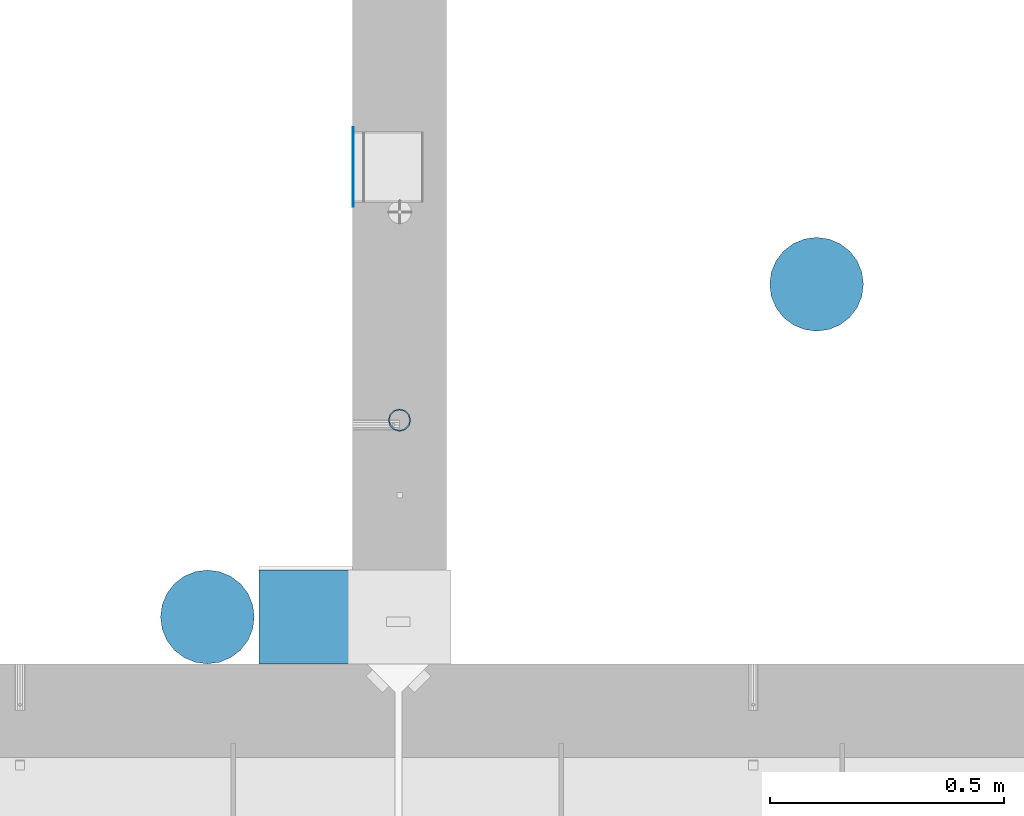
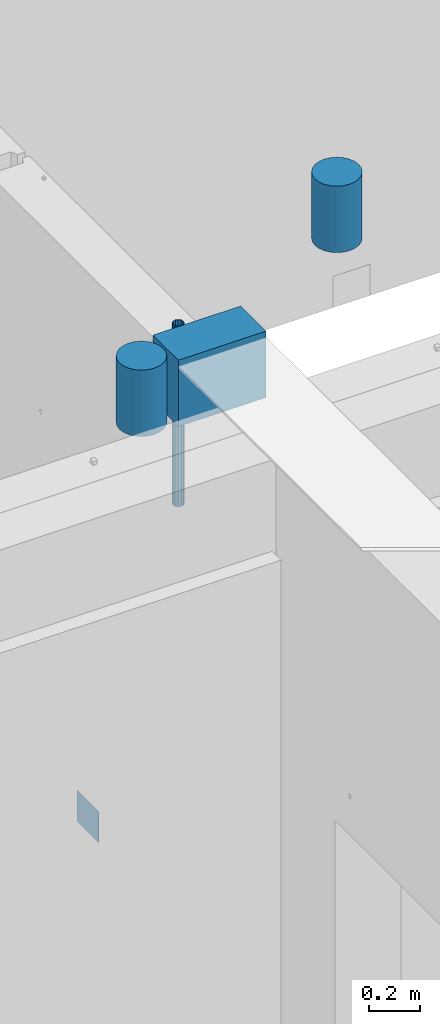
# One storey, part 11 of 264: 5 columns, 5 elements without a shape of their own.
"""IFC2X3 building model written with IfcOpenShell, lengths in millimetres."""

from ifc_helpers import new_model, si_unit, frame, origin_with_axes, place, context, subcontext, project, spatial, faceted_brep, material, type_object, element, aggregate, save


model = new_model("IFC2X3")

# Units and contexts
model_context = context("Model", 3, precision=1e-05, world=origin_with_axes())
body_context = subcontext(model_context, "Body", "Model", "MODEL_VIEW")
ifc_project = project(units=[si_unit("LENGTHUNIT", "METRE", prefix="MILLI"), si_unit("AREAUNIT", "SQUARE_METRE"), si_unit("VOLUMEUNIT", "CUBIC_METRE"), si_unit("MASSUNIT", "GRAM", prefix="KILO"), si_unit("TIMEUNIT", "SECOND"), si_unit("PLANEANGLEUNIT", "RADIAN"), si_unit("SOLIDANGLEUNIT", "STERADIAN"), si_unit("THERMODYNAMICTEMPERATUREUNIT", "DEGREE_CELSIUS"), si_unit("LUMINOUSINTENSITYUNIT", "LUMEN")], contexts=[model_context])

# Site, building, storey
site_placement = place(None, origin_with_axes())
site = spatial("IfcSite", under=ifc_project, at=site_placement, CompositionType="ELEMENT")
building_placement = place(site_placement, origin_with_axes())
building = spatial("IfcBuilding", under=site, at=building_placement, CompositionType="ELEMENT")
storey_placement = place(building_placement, origin_with_axes())
storey = spatial("IfcBuildingStorey", under=building, at=storey_placement, Name="K", CompositionType="ELEMENT", Elevation=0.0)

# Assemblies, columns
assembly_1_placement = place(storey_placement, origin_with_axes())
assembly_1 = element("IfcElementAssembly", 1, at=assembly_1_placement, inside=storey, AssemblyPlace="NOTDEFINED", PredefinedType="REINFORCEMENT_UNIT")
assembly_2_placement = place(assembly_1_placement, origin_with_axes())
assembly_2 = element("IfcElementAssembly", 2, at=assembly_2_placement, Name="Steel Assembly", AssemblyPlace="NOTDEFINED", PredefinedType="NOTDEFINED")
ifc_material_1 = material(Name="Undefined")
column_type_1 = type_object("IfcColumnType", PredefinedType="NOTDEFINED")
column_1_placement = place(assembly_2_placement, frame((28511.0, 14239.9996249472, 78775.0000000357), z_axis=(-1.0, 3.00000001838171e-08, 0.0), x_axis=(0.0, 0.0, 1.0)))
column_1 = element("IfcColumn", 3, at=column_1_placement, type_object=column_type_1, material=ifc_material_1, Name="SPK3", context=body_context, shape_type="Brep", body=[
    faceted_brep([(0.0, 85.0, -1.0), (0.0, 85.0, 1.0), (150.0, 85.0, 1.0), (150.0, 85.0, -1.0), (0.0, -85.0, 1.0), (150.0, -85.0, 1.0), (0.0, -85.0, -1.0), (150.0, -85.0, -1.0)], [[[0, 1, 2, 3]], [[1, 4, 5, 2]], [[4, 6, 7, 5]], [[6, 0, 3, 7]], [[5, 7, 3, 2]], [[6, 4, 1, 0]]]),
])
aggregate(assembly_2, [column_1])
ifc_material_2 = material()
column_type_2 = type_object("IfcColumnType", Name="48.3X2.6", PredefinedType="NOTDEFINED")
column_2_placement = place(assembly_1_placement, frame((28609.9991042544, 13700.0, 80650.0), z_axis=(-1.0, 3.00000001838171e-08, 0.0), x_axis=(0.0, 0.0, 1.0)))
column_2 = element("IfcColumn", 4, at=column_2_placement, type_object=column_type_2, material=ifc_material_2, ObjectType="48.3X2.6", context=body_context, shape_type="Brep", body=[
    faceted_brep([(0.0, -21.5499999999993, 0.0), (0.0, -18.6628474515564, 10.7750000000015), (870.0, -18.6628474515564, 10.7750000000015), (870.0, -21.5499999999993, 0.0), (0.0, -10.7750000000015, 18.6628474515564), (870.0, -10.7750000000015, 18.6628474515564), (0.0, 0.0, 21.5499999999993), (870.0, 0.0, 21.5499999999993), (0.0, 10.7750000000015, 18.6628474515564), (870.0, 10.7750000000015, 18.6628474515564), (0.0, 18.6628474515564, 10.7750000000015), (870.0, 18.6628474515564, 10.7750000000015), (0.0, 21.5499999999993, 0.0), (870.0, 21.5499999999993, 0.0), (0.0, 18.6628474515564, -10.7750000000015), (870.0, 18.6628474515564, -10.7750000000015), (0.0, 10.7750000000015, -18.6628474515564), (870.0, 10.7750000000015, -18.6628474515564), (0.0, 0.0, -21.5499999999993), (870.0, 0.0, -21.5499999999993), (0.0, -10.7750000000015, -18.6628474515564), (870.0, -10.7750000000015, -18.6628474515564), (0.0, -18.6628474515564, -10.7750000000015), (870.0, -18.6628474515564, -10.7750000000015), (0.0, -24.1500000000015, 0.0), (0.0, -20.9145135013932, -12.0750000000007), (870.0, -20.9145135013932, -12.0750000000007), (870.0, -24.1500000000015, 0.0), (0.0, -12.0750000000007, -20.9145135013932), (870.0, -12.0750000000007, -20.9145135013932), (0.0, 0.0, -24.1500000000015), (870.0, 0.0, -24.1500000000015), (0.0, 12.0750000000007, -20.9145135013932), (870.0, 12.0750000000007, -20.9145135013932), (0.0, 20.9145135013932, -12.0750000000007), (870.0, 20.9145135013932, -12.0750000000007), (0.0, 24.1500000000015, 0.0), (870.0, 24.1500000000015, 0.0), (0.0, 20.9145135013932, 12.0750000000007), (870.0, 20.9145135013932, 12.0750000000007), (0.0, 12.0750000000007, 20.9145135013932), (870.0, 12.0750000000007, 20.9145135013932), (0.0, 0.0, 24.1500000000015), (870.0, 0.0, 24.1500000000015), (0.0, -12.0750000000007, 20.9145135013932), (870.0, -12.0750000000007, 20.9145135013932), (0.0, -20.9145135013932, 12.0750000000007), (870.0, -20.9145135013932, 12.0750000000007)], [[[0, 1, 2, 3]], [[1, 4, 5, 2]], [[4, 6, 7, 5]], [[6, 8, 9, 7]], [[8, 10, 11, 9]], [[10, 12, 13, 11]], [[12, 14, 15, 13]], [[14, 16, 17, 15]], [[16, 18, 19, 17]], [[18, 20, 21, 19]], [[20, 22, 23, 21]], [[22, 0, 3, 23]], [[24, 25, 26, 27]], [[25, 28, 29, 26]], [[28, 30, 31, 29]], [[30, 32, 33, 31]], [[32, 34, 35, 33]], [[34, 36, 37, 35]], [[36, 38, 39, 37]], [[38, 40, 41, 39]], [[40, 42, 43, 41]], [[42, 44, 45, 43]], [[44, 46, 47, 45]], [[46, 24, 27, 47]], [[29, 31, 33, 35, 37, 39, 41, 43, 45, 47, 27, 26], [5, 7, 9, 11, 13, 15, 17, 19, 21, 23, 3, 2]], [[46, 44, 42, 40, 38, 36, 34, 32, 30, 28, 25, 24], [22, 20, 18, 16, 14, 12, 10, 8, 6, 4, 1, 0]]]),
])
aggregate(assembly_1, [column_2, assembly_2])

# Assembly, column
assembly_3_placement = place(storey_placement, origin_with_axes())
assembly_3 = element("IfcElementAssembly", 5, at=assembly_3_placement, inside=storey, Name="Steel Assembly", AssemblyPlace="NOTDEFINED", PredefinedType="NOTDEFINED")
ifc_material_3 = material()
column_type_3 = type_object("IfcColumnType", Name="D200", PredefinedType="NOTDEFINED")
column_3_placement = place(assembly_3_placement, frame((29500.0007614493, 13989.9999603629, 81440.0), z_axis=(0.0, 1.0, 0.0), x_axis=(0.0, 0.0, 1.0)))
column_3 = element("IfcColumn", 6, at=column_3_placement, type_object=column_type_3, material=ifc_material_3, ObjectType="D200", context=body_context, shape_type="Brep", body=[
    faceted_brep([(0.0, -100.0, 0.0), (0.0, -96.5925826289022, -25.8819045102518), (320.0, -96.5925826289058, -25.8819045102518), (320.0, -100.0, 0.0), (0.0, -86.6025403784442, -50.0), (320.0, -86.6025403784442, -50.0), (0.0, -70.7106781186594, -70.710678118654), (320.0, -70.7106781186558, -70.710678118654), (0.0, -50.0, -86.6025403784442), (320.0, -50.0, -86.6025403784442), (0.0, -25.8819045102573, -96.5925826289076), (320.0, -25.8819045102537, -96.5925826289076), (0.0, 0.0, -100.0), (320.0, 0.0, -100.0), (0.0, 25.8819045102573, -96.5925826289076), (320.0, 25.8819045102537, -96.5925826289076), (0.0, 50.0, -86.6025403784442), (320.0, 50.0, -86.6025403784442), (0.0, 70.7106781186594, -70.710678118654), (320.0, 70.7106781186558, -70.710678118654), (0.0, 86.6025403784442, -50.0), (320.0, 86.6025403784442, -50.0), (0.0, 96.5925826289022, -25.8819045102518), (320.0, 96.5925826289058, -25.8819045102518), (0.0, 100.0, 0.0), (320.0, 100.0, 0.0), (0.0, 96.5925826289022, 25.8819045102518), (320.0, 96.5925826289058, 25.8819045102518), (0.0, 86.6025403784442, 50.0), (320.0, 86.6025403784442, 50.0), (0.0, 70.7106781186594, 70.710678118654), (320.0, 70.7106781186558, 70.710678118654), (0.0, 50.0, 86.6025403784442), (320.0, 50.0, 86.6025403784442), (0.0, 25.8819045102573, 96.5925826289076), (320.0, 25.8819045102537, 96.5925826289076), (0.0, 0.0, 100.0), (320.0, 0.0, 100.0), (0.0, -25.8819045102573, 96.5925826289076), (320.0, -25.8819045102537, 96.5925826289076), (0.0, -50.0, 86.6025403784442), (320.0, -50.0, 86.6025403784442), (0.0, -70.7106781186594, 70.710678118654), (320.0, -70.7106781186558, 70.710678118654), (0.0, -86.6025403784442, 50.0), (320.0, -86.6025403784442, 50.0), (0.0, -96.5925826289022, 25.8819045102518), (320.0, -96.5925826289058, 25.8819045102518)], [[[0, 1, 2, 3]], [[1, 4, 5, 2]], [[4, 6, 7, 5]], [[6, 8, 9, 7]], [[8, 10, 11, 9]], [[10, 12, 13, 11]], [[12, 14, 15, 13]], [[14, 16, 17, 15]], [[16, 18, 19, 17]], [[18, 20, 21, 19]], [[20, 22, 23, 21]], [[22, 24, 25, 23]], [[24, 26, 27, 25]], [[26, 28, 29, 27]], [[28, 30, 31, 29]], [[30, 32, 33, 31]], [[32, 34, 35, 33]], [[34, 36, 37, 35]], [[36, 38, 39, 37]], [[38, 40, 41, 39]], [[40, 42, 43, 41]], [[42, 44, 45, 43]], [[44, 46, 47, 45]], [[46, 0, 3, 47]], [[5, 7, 9, 11, 13, 15, 17, 19, 21, 23, 25, 27, 29, 31, 33, 35, 37, 39, 41, 43, 45, 47, 3, 2]], [[46, 44, 42, 40, 38, 36, 34, 32, 30, 28, 26, 24, 22, 20, 18, 16, 14, 12, 10, 8, 6, 4, 1, 0]]]),
])
aggregate(assembly_3, [column_3])

assembly_4_placement = place(storey_placement, origin_with_axes())
assembly_4 = element("IfcElementAssembly", 7, at=assembly_4_placement, inside=storey, Name="Steel Assembly", AssemblyPlace="NOTDEFINED", PredefinedType="NOTDEFINED")
column_4_placement = place(assembly_4_placement, frame((28199.9996170402, 13279.9999222159, 81440.0), z_axis=(0.0, 1.0, 0.0), x_axis=(0.0, 0.0, 1.0)))
column_4 = element("IfcColumn", 8, at=column_4_placement, type_object=column_type_3, material=ifc_material_3, ObjectType="D200", context=body_context, shape_type="Brep", body=[
    faceted_brep([(0.0, -100.0, 0.0), (0.0, -96.5925826289022, -25.8819045102518), (320.0, -96.5925826289058, -25.8819045102518), (320.0, -100.0, 0.0), (0.0, -86.6025403784442, -50.0), (320.0, -86.6025403784442, -50.0), (0.0, -70.7106781186594, -70.710678118654), (320.0, -70.7106781186558, -70.710678118654), (0.0, -50.0, -86.6025403784442), (320.0, -50.0, -86.6025403784442), (0.0, -25.8819045102573, -96.5925826289076), (320.0, -25.8819045102537, -96.5925826289076), (0.0, 0.0, -100.0), (320.0, 0.0, -100.0), (0.0, 25.8819045102573, -96.5925826289076), (320.0, 25.8819045102537, -96.5925826289076), (0.0, 50.0, -86.6025403784442), (320.0, 50.0, -86.6025403784442), (0.0, 70.7106781186594, -70.710678118654), (320.0, 70.7106781186558, -70.710678118654), (0.0, 86.6025403784442, -50.0), (320.0, 86.6025403784442, -50.0), (0.0, 96.5925826289022, -25.8819045102518), (320.0, 96.5925826289058, -25.8819045102518), (0.0, 100.0, 0.0), (320.0, 100.0, 0.0), (0.0, 96.5925826289022, 25.8819045102518), (320.0, 96.5925826289058, 25.8819045102518), (0.0, 86.6025403784442, 50.0), (320.0, 86.6025403784442, 50.0), (0.0, 70.7106781186594, 70.710678118654), (320.0, 70.7106781186558, 70.710678118654), (0.0, 50.0, 86.6025403784442), (320.0, 50.0, 86.6025403784442), (0.0, 25.8819045102573, 96.5925826289076), (320.0, 25.8819045102537, 96.5925826289076), (0.0, 0.0, 100.0), (320.0, 0.0, 100.0), (0.0, -25.8819045102573, 96.5925826289076), (320.0, -25.8819045102537, 96.5925826289076), (0.0, -50.0, 86.6025403784442), (320.0, -50.0, 86.6025403784442), (0.0, -70.7106781186594, 70.710678118654), (320.0, -70.7106781186558, 70.710678118654), (0.0, -86.6025403784442, 50.0), (320.0, -86.6025403784442, 50.0), (0.0, -96.5925826289022, 25.8819045102518), (320.0, -96.5925826289058, 25.8819045102518)], [[[0, 1, 2, 3]], [[1, 4, 5, 2]], [[4, 6, 7, 5]], [[6, 8, 9, 7]], [[8, 10, 11, 9]], [[10, 12, 13, 11]], [[12, 14, 15, 13]], [[14, 16, 17, 15]], [[16, 18, 19, 17]], [[18, 20, 21, 19]], [[20, 22, 23, 21]], [[22, 24, 25, 23]], [[24, 26, 27, 25]], [[26, 28, 29, 27]], [[28, 30, 31, 29]], [[30, 32, 33, 31]], [[32, 34, 35, 33]], [[34, 36, 37, 35]], [[36, 38, 39, 37]], [[38, 40, 41, 39]], [[40, 42, 43, 41]], [[42, 44, 45, 43]], [[44, 46, 47, 45]], [[46, 0, 3, 47]], [[5, 7, 9, 11, 13, 15, 17, 19, 21, 23, 25, 27, 29, 31, 33, 35, 37, 39, 41, 43, 45, 47, 3, 2]], [[46, 44, 42, 40, 38, 36, 34, 32, 30, 28, 26, 24, 22, 20, 18, 16, 14, 12, 10, 8, 6, 4, 1, 0]]]),
])
aggregate(assembly_4, [column_4])

assembly_5_placement = place(storey_placement, origin_with_axes())
assembly_5 = element("IfcElementAssembly", 9, at=assembly_5_placement, inside=storey, Name="Steel Assembly", AssemblyPlace="NOTDEFINED", PredefinedType="NOTDEFINED")
column_type_4 = type_object("IfcColumnType", PredefinedType="NOTDEFINED")
column_5_placement = place(assembly_5_placement, frame((28510.0, 13279.9999222159, 81440.0), z_axis=(-1.0, 3.00000001838171e-08, 0.0), x_axis=(0.0, 0.0, 1.0)))
column_5 = element("IfcColumn", 10, at=column_5_placement, type_object=column_type_4, material=ifc_material_3, context=body_context, shape_type="Brep", body=[
    faceted_brep([(0.0, 100.0, -200.0), (0.0, 100.0, 200.0), (320.0, 100.0, 200.0), (320.0, 100.0, -200.0), (0.0, -100.0, 200.0), (320.0, -100.0, 200.0), (0.0, -100.0, -200.0), (320.0, -100.0, -200.0)], [[[0, 1, 2, 3]], [[1, 4, 5, 2]], [[4, 6, 7, 5]], [[6, 0, 3, 7]], [[5, 7, 3, 2]], [[6, 4, 1, 0]]]),
])
aggregate(assembly_5, [column_5])

save(model, "model.ifc")
